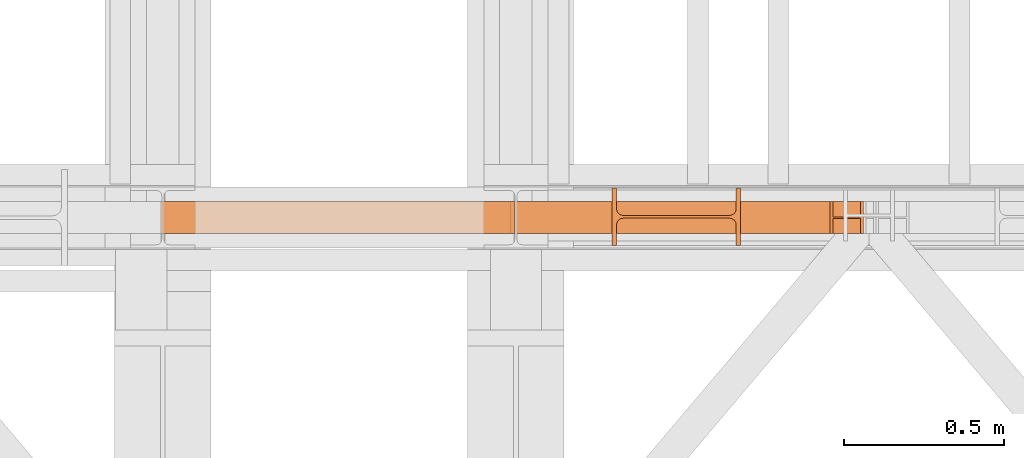
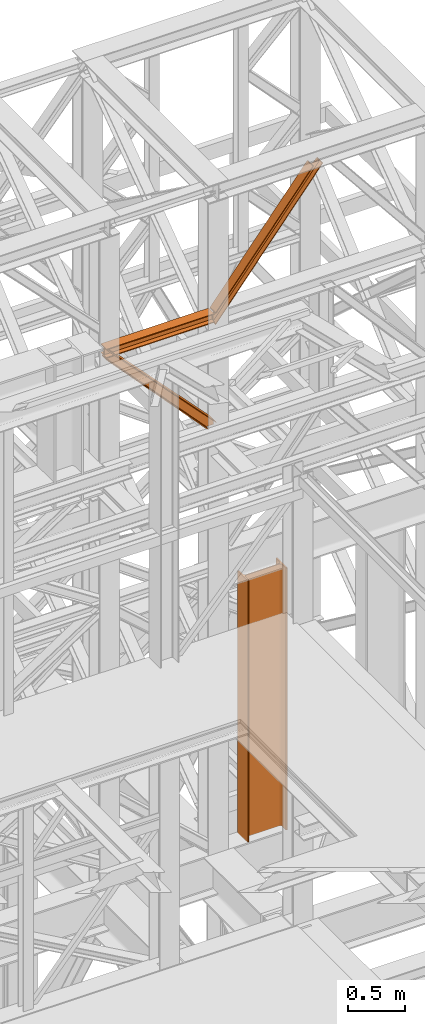
# One storey, part 154 of 208: 4 proxies.
"""IFC2X3 building model written with IfcOpenShell, lengths in millimetres."""

import ifcopenshell
import ifcopenshell.guid

model = None  # the IFC model being written
_history = None  # IfcOwnerHistory: only IFC2X3 demands one
_inside = {}  # id of a spatial element -> (the spatial element, [elements in it])
_under = {}  # id of a project, library or spatial element -> (it, [spatial elements below it])
_declared = {}  # id of a project -> (the project, [libraries it declares])
_typed = {}  # id of a type object -> (the type object, [elements of that type])
_made_of = {}  # id of a material, layer set ... -> (it, [elements and type objects made of it])


def new_model(schema):
    """Start an empty IFC model of exactly this schema.

    Asked for "IFC4X3", IfcOpenShell would pick the latest addendum, in which some entities
    have other attributes; the version numbers below select the first issue.
    IFC2X3 requires an IfcOwnerHistory on every rooted entity: one is made here for all.
    """
    global model, _history
    if schema == "IFC4X3":
        model = ifcopenshell.file(schema_version=(4, 3, 0, 0))
    else:
        model = ifcopenshell.file(schema=schema)
    _inside.clear()
    _under.clear()
    _declared.clear()
    _typed.clear()
    _made_of.clear()
    _history = None
    if model.schema == "IFC2X3":
        org = make("IfcOrganization", Name="unknown")
        user = make(
            "IfcPersonAndOrganization",
            ThePerson=make("IfcPerson", FamilyName="unknown"),
            TheOrganization=org,
        )
        app = make(
            "IfcApplication",
            ApplicationDeveloper=org,
            Version="unknown",
            ApplicationFullName="unknown",
            ApplicationIdentifier="unknown",
        )
        _history = make(
            "IfcOwnerHistory",
            OwningUser=user,
            OwningApplication=app,
            ChangeAction="ADDED",
            CreationDate=0,
        )
    return model


def make(cls, **values):
    """One entity of the class cls with the attributes given. An attribute that is None is left unset."""
    return model.create_entity(
        cls, **{name: value for name, value in values.items() if value is not None}
    )


def entity(cls, *values):
    """Any entity or typed value of the class cls, its attributes in the order of the schema. None: left unset."""
    e = model.create_entity(cls)
    for i, value in enumerate(values):
        if value is not None:
            e[i] = value
    return e


def rooted(cls, **values):
    """An entity with a GlobalId (a new one), such as an element, a storey or a relation."""
    return make(cls, GlobalId=ifcopenshell.guid.new(), OwnerHistory=_history, **values)


def si_unit(unit_type, name, prefix=None):
    """IfcSIUnit, for example si_unit("LENGTHUNIT", "METRE", prefix="MILLI")."""
    return make("IfcSIUnit", UnitType=unit_type, Prefix=prefix, Name=name)


def converted_unit(unit_type, name, factor, base, dimensions=None, offset=None):
    """IfcConversionBasedUnit, such as the inch: factor (a typed value) times the base unit."""
    return make(
        "IfcConversionBasedUnit"
        if offset is None
        else "IfcConversionBasedUnitWithOffset",
        ConversionOffset=offset,
        Dimensions=None
        if dimensions is None
        else entity("IfcDimensionalExponents", *dimensions),
        UnitType=unit_type,
        Name=name,
        ConversionFactor=make(
            "IfcMeasureWithUnit", ValueComponent=factor, UnitComponent=base
        ),
    )


def assignment(units):
    """IfcUnitAssignment: the units of a project."""
    return None if units is None else make("IfcUnitAssignment", Units=units)


def point(xyz):
    """IfcCartesianPoint."""
    return None if xyz is None else make("IfcCartesianPoint", Coordinates=xyz)


def direction(xyz):
    """IfcDirection."""
    return None if xyz is None else make("IfcDirection", DirectionRatios=xyz)


def frame(location, z_axis=None, x_axis=None):
    """IfcAxis2Placement3D, a coordinate frame: its origin and axes. An axis left out is left unset."""
    return make(
        "IfcAxis2Placement3D",
        Location=point(location),
        Axis=direction(z_axis),
        RefDirection=direction(x_axis),
    )


def origin():
    """The frame at (0, 0, 0) with its axes left unset."""
    return frame((0.0, 0.0, 0.0))


def origin_with_axes():
    """The frame at (0, 0, 0) with the z axis (0, 0, 1) and the x axis (1, 0, 0) written out."""
    return frame((0.0, 0.0, 0.0), z_axis=(0.0, 0.0, 1.0), x_axis=(1.0, 0.0, 0.0))


def place(relative_to, where):
    """IfcLocalPlacement: puts the frame where relative to a parent placement (None: the world)."""
    return make(
        "IfcLocalPlacement", PlacementRelTo=relative_to, RelativePlacement=where
    )


def context(
    kind, dimensions, precision=None, world=None, true_north=None, identifier=None
):
    """IfcGeometricRepresentationContext, for example the 3D "Model" context."""
    return make(
        "IfcGeometricRepresentationContext",
        ContextIdentifier=identifier,
        ContextType=kind,
        CoordinateSpaceDimension=dimensions,
        Precision=precision,
        WorldCoordinateSystem=world,
        TrueNorth=true_north,
    )


def subcontext(parent, identifier, kind, view, scale=None):
    """IfcGeometricRepresentationSubContext, for example "Body" below "Model"."""
    return make(
        "IfcGeometricRepresentationSubContext",
        ContextIdentifier=identifier,
        ContextType=kind,
        ParentContext=parent,
        TargetScale=scale,
        TargetView=view,
    )


def project(units=None, contexts=None):
    """IfcProject with its units and contexts."""
    return rooted(
        "IfcProject",
        Name="project",
        RepresentationContexts=contexts,
        UnitsInContext=assignment(units),
    )


def spatial(cls, under=None, at=None, **own):
    """A site, building, storey or space (cls), placed at a placement, below another one or the project."""
    s = rooted(cls, ObjectPlacement=at, **own)
    if under is not None:
        _under.setdefault(under.id(), (under, []))[1].append(s)
    return s


def faces_of(points, faces, orient=None, outer=None):
    """IfcFace entities. A face is a list of loops; a loop is a list of indices into points, from 0.

    orient and outer hold one flag for each loop. By default every Orientation is true, the
    first loop of a face is its IfcFaceOuterBound and the others are IfcFaceBound.
    """
    made = []
    for i, loops in enumerate(faces):
        bounds = []
        for j, loop in enumerate(loops):
            is_outer = j == 0 if outer is None else outer[i][j]
            bounds.append(
                make(
                    "IfcFaceOuterBound" if is_outer else "IfcFaceBound",
                    Bound=make("IfcPolyLoop", Polygon=[points[k] for k in loop]),
                    Orientation=True if orient is None else orient[i][j],
                )
            )
        made.append(make("IfcFace", Bounds=bounds))
    return made


def faceted_brep(points, faces, orient=None, outer=None, voids=None):
    """IfcFacetedBrep: a solid bounded by flat faces; with voids (closed shells), ...WithVoids."""
    shared = [point(p) for p in points]
    hull = make("IfcClosedShell", CfsFaces=faces_of(shared, faces, orient, outer))
    if voids is None:
        return make("IfcFacetedBrep", Outer=hull)
    return make(
        "IfcFacetedBrepWithVoids",
        Outer=hull,
        Voids=[
            make(cls, CfsFaces=faces_of(shared, fs, o, b)) for cls, fs, o, b in voids
        ],
    )


def shape(context_of_items, identifier, shape_type, items):
    """IfcShapeRepresentation: the items that make up one representation, for example the "Body"."""
    return make(
        "IfcShapeRepresentation",
        ContextOfItems=context_of_items,
        RepresentationIdentifier=identifier,
        RepresentationType=shape_type,
        Items=items,
    )


def made_of(thing, what):
    """Note that an element or type object is made of a material, layer set ...; save() writes the relation."""
    if what is not None:
        _made_of.setdefault(what.id(), (what, []))[1].append(thing)
    return thing


def element(
    cls,
    number,
    at=None,
    inside=None,
    cuts=None,
    type_object=None,
    material=None,
    context=None,
    identifier="Body",
    shape_type=None,
    held_by="IfcProductDefinitionShape",
    body=None,
    shapes=None,
    **own,
):
    """One element of the class cls, such as IfcWall. Its Tag is "e" and its number.

    at: its placement. inside: the storey or other place that contains it. cuts: it is an
    opening in that element (IfcRelVoidsElement). A single representation is given by context,
    identifier, shape_type and body (its items); several are given by shapes. held_by: the class
    of the entity that holds the representations. save() writes the other relations.
    """
    e = rooted(cls, Tag="e%d" % number, ObjectPlacement=at, **own)
    if body is not None:
        shapes = [shape(context, identifier, shape_type, body)]
    if shapes is not None:
        e.Representation = make(held_by, Representations=shapes)
    if inside is not None:
        _inside.setdefault(inside.id(), (inside, []))[1].append(e)
    if cuts is not None:
        rooted(
            "IfcRelVoidsElement", RelatingBuildingElement=cuts, RelatedOpeningElement=e
        )
    if type_object is not None:
        _typed.setdefault(type_object.id(), (type_object, []))[1].append(e)
    return made_of(e, material)


def aggregate(whole, parts):
    """IfcRelAggregates: a whole, such as a stair, and the parts it consists of."""
    return rooted("IfcRelAggregates", RelatingObject=whole, RelatedObjects=parts)


def save(model, path):
    """Write the relations noted so far, then the file.

    IfcRelAggregates (storeys below a building ...), IfcRelContainedInSpatialStructure (elements
    in a storey), IfcRelDefinesByType, IfcRelAssociatesMaterial and IfcRelDeclares: one each for
    every whole, place, type object, material and project.
    """
    for whole, parts in _under.values():
        aggregate(whole, parts)
    for where, things in _inside.values():
        rooted(
            "IfcRelContainedInSpatialStructure",
            RelatedElements=things,
            RelatingStructure=where,
        )
    for kind, things in _typed.values():
        rooted("IfcRelDefinesByType", RelatedObjects=things, RelatingType=kind)
    for what, things in _made_of.values():
        rooted("IfcRelAssociatesMaterial", RelatedObjects=things, RelatingMaterial=what)
    for by, libraries in _declared.values():
        rooted("IfcRelDeclares", RelatingContext=by, RelatedDefinitions=libraries)
    model.write(path)


model = new_model("IFC2X3")

# Units and contexts
model_context = context("Model", 3, precision=1e-05, world=origin())
plan_context = context("Plan", 3, precision=1e-05, world=origin())
body_context = subcontext(model_context, "Body", "Model", "MODEL_VIEW")
ifc_project = project(units=[si_unit("LENGTHUNIT", "METRE", prefix="MILLI"), converted_unit("PLANEANGLEUNIT", "DEGREE", entity("IfcPlaneAngleMeasure", 0.0174532925199433), si_unit("PLANEANGLEUNIT", "RADIAN"), dimensions=[0, 0, 0, 0, 0, 0, 0]), si_unit("AREAUNIT", "SQUARE_METRE"), si_unit("VOLUMEUNIT", "CUBIC_METRE")], contexts=[model_context, plan_context])

# Building, storey
building_placement = place(None, origin())
building = spatial("IfcBuilding", under=ifc_project, at=building_placement, CompositionType="COMPLEX")
storey_placement = place(building_placement, origin_with_axes())
storey = spatial("IfcBuildingStorey", under=building, at=storey_placement, Name="Geschoss", CompositionType="ELEMENT")

# Proxies
proxy_1_placement = place(storey_placement, frame((6893.254968528654, -16050.07439031789, 5278.356417081654), z_axis=(0.0, 0.0, 1.0), x_axis=(1.0, 0.0, 0.0)))
element("IfcBuildingElementProxy", 1, at=proxy_1_placement, inside=storey, context=body_context, shape_type="Brep", body=[
    faceted_brep([(400.0100000000002, 180.0100000000002, 0.01000000000112777), (400.0100000000002, 180.0100000000002, 2800.009999999993), (386.5100000000002, 180.0100000000002, 2800.009999999993), (386.5100000000002, 180.0100000000002, 0.01000000000112777), (386.5100000000002, 180.0100000000002, 0.01000000000112777), (386.5100000000002, 180.0100000000002, 2800.009999999993), (386.5100000000002, 115.3100001907351, 2800.009999999993), (386.5100000000002, 115.3100001907351, 0.01000000000112777), (386.5100000000002, 115.3100001907351, 0.01000000000112777), (386.5100000000002, 115.3100001907351, 2800.009999999993), (385.4821152884242, 108.820665321733, 2800.009999999993), (385.4821152884242, 108.820665321733, 0.01000000000112777), (385.4821152884242, 108.820665321733, 0.01000000000112777), (385.4821152884242, 108.820665321733, 2800.009999999993), (382.49933091598, 102.9665306951119, 2800.009999999993), (382.49933091598, 102.9665306951119, 0.01000000000112777), (382.49933091598, 102.9665306951119, 0.01000000000112777), (382.49933091598, 102.9665306951119, 2800.009999999993), (377.8534694956243, 98.32066927475717, 2800.009999999993), (377.8534694956243, 98.32066927475717, 0.01000000000112777), (377.8534694956243, 98.32066927475717, 0.01000000000112777), (377.8534694956243, 98.32066927475717, 2800.009999999993), (371.9993348690032, 95.337884902312, 2800.009999999993), (371.9993348690032, 95.337884902312, 0.01000000000112777), (371.9993348690032, 95.337884902312, 0.01000000000112777), (371.9993348690032, 95.337884902312, 2800.009999999993), (365.5100000000002, 94.31000019073508, 2800.009999999993), (365.5100000000002, 94.31000019073508, 0.01000000000112777), (365.5100000000002, 94.31000019073508, 0.01000000000112777), (365.5100000000002, 94.31000019073508, 2800.009999999993), (34.51000000000022, 94.31000019073508, 2800.009999999993), (34.51000000000022, 94.31000019073508, 0.01000000000021828), (34.51000000000022, 94.31000019073508, 0.01000000000021828), (34.51000000000022, 94.31000019073508, 2800.009999999993), (28.02066513099817, 95.337884902312, 2800.009999999993), (28.02066513099817, 95.337884902312, 0.01000000000021828), (28.02066513099817, 95.337884902312, 0.01000000000021828), (28.02066513099817, 95.337884902312, 2800.009999999993), (22.16653050437708, 98.32066927475717, 2800.009999999993), (22.16653050437708, 98.32066927475717, 0.01000000000021828), (22.16653050437708, 98.32066927475717, 0.01000000000021828), (22.16653050437708, 98.32066927475717, 2800.009999999993), (17.52066908402139, 102.9665306951119, 2800.009999999993), (17.52066908402139, 102.9665306951119, 0.01000000000021828), (17.52066908402139, 102.9665306951119, 0.01000000000021828), (17.52066908402139, 102.9665306951119, 2800.009999999993), (14.53788471157623, 108.820665321733, 2800.009999999993), (14.53788471157623, 108.820665321733, 0.01000000000021828), (14.53788471157623, 108.820665321733, 0.01000000000021828), (14.53788471157623, 108.820665321733, 2800.009999999993), (13.51000000000022, 115.3100001907351, 2800.009999999993), (13.51000000000022, 115.3100001907351, 0.01000000000021828), (13.51000000000022, 115.3100001907351, 0.01000000000021828), (13.51000000000022, 115.3100001907351, 2800.009999999993), (13.51000000000022, 180.0100000000002, 2800.009999999993), (13.51000000000022, 180.0100000000002, 0.01000000000021828), (13.51000000000022, 180.0100000000002, 0.01000000000021828), (13.51000000000022, 180.0100000000002, 2800.009999999993), (0.01000000000021828, 180.0100000000002, 2800.009999999993), (0.01000000000021828, 180.0100000000002, 0.01000000000021828), (0.01000000000021828, 180.0100000000002, 0.01000000000021828), (0.01000000000021828, 180.0100000000002, 2800.009999999993), (0.01000000000021828, 0.01000000000021828, 2800.009999999993), (0.01000000000021828, 0.01000000000021828, 0.01000000000021828), (0.01000000000021828, 0.01000000000021828, 0.01000000000021828), (0.01000000000021828, 0.01000000000021828, 2800.009999999993), (13.51000000000022, 0.01000000000021828, 2800.009999999993), (13.51000000000022, 0.01000000000021828, 0.01000000000021828), (13.51000000000022, 0.01000000000021828, 0.01000000000021828), (13.51000000000022, 0.01000000000021828, 2800.009999999993), (13.51000000000022, 64.70999980926535, 2800.009999999993), (13.51000000000022, 64.70999980926535, 0.01000000000021828), (13.51000000000022, 64.70999980926535, 0.01000000000021828), (13.51000000000022, 64.70999980926535, 2800.009999999993), (14.53788471157623, 71.1993346782674, 2800.009999999993), (14.53788471157623, 71.1993346782674, 0.01000000000021828), (14.53788471157623, 71.1993346782674, 0.01000000000021828), (14.53788471157623, 71.1993346782674, 2800.009999999993), (17.52066908402139, 77.0534693048885, 2800.009999999993), (17.52066908402139, 77.0534693048885, 0.01000000000021828), (17.52066908402139, 77.0534693048885, 0.01000000000021828), (17.52066908402139, 77.0534693048885, 2800.009999999993), (22.16653050437708, 81.69933072524327, 2800.009999999993), (22.16653050437708, 81.69933072524327, 0.01000000000021828), (22.16653050437708, 81.69933072524327, 0.01000000000021828), (22.16653050437708, 81.69933072524327, 2800.009999999993), (28.02066513099817, 84.68211509768844, 2800.009999999993), (28.02066513099817, 84.68211509768844, 0.01000000000021828), (28.02066513099817, 84.68211509768844, 0.01000000000021828), (28.02066513099817, 84.68211509768844, 2800.009999999993), (34.51000000000022, 85.70999980926535, 2800.009999999993), (34.51000000000022, 85.70999980926535, 0.01000000000021828), (34.51000000000022, 85.70999980926535, 0.01000000000021828), (34.51000000000022, 85.70999980926535, 2800.009999999993), (365.5100000000002, 85.70999980926535, 2800.009999999993), (365.5100000000002, 85.70999980926535, 0.01000000000112777), (365.5100000000002, 85.70999980926535, 0.01000000000112777), (365.5100000000002, 85.70999980926535, 2800.009999999993), (370.9451817183826, 84.99438062176887, 2800.009999999993), (370.9451817183826, 84.99438062176887, 0.01000000000112777), (370.9451817183826, 84.99438062176887, 0.01000000000112777), (370.9451817183826, 84.99438062176887, 2800.009999999993), (376.0099693746442, 82.89647688400692, 2800.009999999993), (376.0099693746442, 82.89647688400692, 0.01000000000112777), (376.0099693746442, 82.89647688400692, 0.01000000000112777), (376.0099693746442, 82.89647688400692, 2800.009999999993), (380.3592424049184, 79.55924221418354, 2800.009999999993), (380.3592424049184, 79.55924221418354, 0.01000000000112777), (380.3592424049184, 79.55924221418354, 0.01000000000112777), (380.3592424049184, 79.55924221418354, 2800.009999999993), (383.6964770747418, 75.20996918390847, 2800.009999999993), (383.6964770747418, 75.20996918390847, 0.01000000000112777), (383.6964770747418, 75.20996918390847, 0.01000000000112777), (383.6964770747418, 75.20996918390847, 2800.009999999993), (385.7943808125056, 70.14518152764686, 2800.009999999993), (385.7943808125056, 70.14518152764686, 0.01000000000112777), (385.7943808125056, 70.14518152764686, 0.01000000000112777), (385.7943808125056, 70.14518152764686, 2800.009999999993), (386.5100000000002, 64.70999980926535, 2800.009999999993), (386.5100000000002, 64.70999980926535, 0.01000000000112777), (386.5100000000002, 64.70999980926535, 0.01000000000112777), (386.5100000000002, 64.70999980926535, 2800.009999999993), (386.5100000000002, 0.01000000000021828, 2800.009999999993), (386.5100000000002, 0.01000000000021828, 0.01000000000112777), (386.5100000000002, 0.01000000000021828, 0.01000000000112777), (386.5100000000002, 0.01000000000021828, 2800.009999999993), (400.0100000000002, 0.01000000000021828, 2800.009999999993), (400.0100000000002, 0.01000000000021828, 0.01000000000112777), (400.0100000000002, 0.01000000000021828, 0.01000000000112777), (400.0100000000002, 0.01000000000021828, 2800.009999999993), (400.0100000000002, 180.0100000000002, 2800.009999999993), (400.0100000000002, 180.0100000000002, 0.01000000000112777), (400.0100000000002, 180.0100000000002, 0.01000000000112777), (386.5100000000002, 180.0100000000002, 0.01000000000112777), (386.5100000000002, 115.3100001907351, 0.01000000000112777), (385.4821152884242, 108.820665321733, 0.01000000000112777), (382.49933091598, 102.9665306951119, 0.01000000000112777), (377.8534694956243, 98.32066927475717, 0.01000000000112777), (371.9993348690032, 95.337884902312, 0.01000000000112777), (365.5100000000002, 94.31000019073508, 0.01000000000112777), (34.51000000000022, 94.31000019073508, 0.01000000000021828), (28.02066513099817, 95.337884902312, 0.01000000000021828), (22.16653050437708, 98.32066927475717, 0.01000000000021828), (17.52066908402139, 102.9665306951119, 0.01000000000021828), (14.53788471157623, 108.820665321733, 0.01000000000021828), (13.51000000000022, 115.3100001907351, 0.01000000000021828), (13.51000000000022, 180.0100000000002, 0.01000000000021828), (0.01000000000021828, 180.0100000000002, 0.01000000000021828), (0.01000000000021828, 0.01000000000021828, 0.01000000000021828), (13.51000000000022, 0.01000000000021828, 0.01000000000021828), (13.51000000000022, 64.70999980926535, 0.01000000000021828), (14.53788471157623, 71.1993346782674, 0.01000000000021828), (17.52066908402139, 77.0534693048885, 0.01000000000021828), (22.16653050437708, 81.69933072524327, 0.01000000000021828), (28.02066513099817, 84.68211509768844, 0.01000000000021828), (34.51000000000022, 85.70999980926535, 0.01000000000021828), (365.5100000000002, 85.70999980926535, 0.01000000000112777), (370.9451817183826, 84.99438062176887, 0.01000000000112777), (376.0099693746442, 82.89647688400692, 0.01000000000112777), (380.3592424049184, 79.55924221418354, 0.01000000000112777), (383.6964770747418, 75.20996918390847, 0.01000000000112777), (385.7943808125056, 70.14518152764686, 0.01000000000112777), (386.5100000000002, 64.70999980926535, 0.01000000000112777), (386.5100000000002, 0.01000000000021828, 0.01000000000112777), (400.0100000000002, 0.01000000000021828, 0.01000000000112777), (400.0100000000002, 180.0100000000002, 2800.009999999993), (400.0100000000002, 0.01000000000021828, 2800.009999999993), (386.5100000000002, 0.01000000000021828, 2800.009999999993), (386.5100000000002, 64.70999980926535, 2800.009999999993), (385.7943808125056, 70.14518152764686, 2800.009999999993), (383.6964770747418, 75.20996918390847, 2800.009999999993), (380.3592424049184, 79.55924221418354, 2800.009999999993), (376.0099693746442, 82.89647688400692, 2800.009999999993), (370.9451817183826, 84.99438062176887, 2800.009999999993), (365.5100000000002, 85.70999980926535, 2800.009999999993), (34.51000000000022, 85.70999980926535, 2800.009999999993), (28.02066513099817, 84.68211509768844, 2800.009999999993), (22.16653050437708, 81.69933072524327, 2800.009999999993), (17.52066908402139, 77.0534693048885, 2800.009999999993), (14.53788471157623, 71.1993346782674, 2800.009999999993), (13.51000000000022, 64.70999980926535, 2800.009999999993), (13.51000000000022, 0.01000000000021828, 2800.009999999993), (0.01000000000021828, 0.01000000000021828, 2800.009999999993), (0.01000000000021828, 180.0100000000002, 2800.009999999993), (13.51000000000022, 180.0100000000002, 2800.009999999993), (13.51000000000022, 115.3100001907351, 2800.009999999993), (14.53788471157623, 108.820665321733, 2800.009999999993), (17.52066908402139, 102.9665306951119, 2800.009999999993), (22.16653050437708, 98.32066927475717, 2800.009999999993), (28.02066513099817, 95.337884902312, 2800.009999999993), (34.51000000000022, 94.31000019073508, 2800.009999999993), (365.5100000000002, 94.31000019073508, 2800.009999999993), (371.9993348690032, 95.337884902312, 2800.009999999993), (377.8534694956243, 98.32066927475717, 2800.009999999993), (382.49933091598, 102.9665306951119, 2800.009999999993), (385.4821152884242, 108.820665321733, 2800.009999999993), (386.5100000000002, 115.3100001907351, 2800.009999999993), (386.5100000000002, 180.0100000000002, 2800.009999999993)], [[[0, 1, 2, 3]], [[4, 5, 6, 7]], [[8, 9, 10, 11]], [[12, 13, 14, 15]], [[16, 17, 18, 19]], [[20, 21, 22, 23]], [[24, 25, 26, 27]], [[28, 29, 30, 31]], [[32, 33, 34, 35]], [[36, 37, 38, 39]], [[40, 41, 42, 43]], [[44, 45, 46, 47]], [[48, 49, 50, 51]], [[52, 53, 54, 55]], [[56, 57, 58, 59]], [[60, 61, 62, 63]], [[64, 65, 66, 67]], [[68, 69, 70, 71]], [[72, 73, 74, 75]], [[76, 77, 78, 79]], [[80, 81, 82, 83]], [[84, 85, 86, 87]], [[88, 89, 90, 91]], [[92, 93, 94, 95]], [[96, 97, 98, 99]], [[100, 101, 102, 103]], [[104, 105, 106, 107]], [[108, 109, 110, 111]], [[112, 113, 114, 115]], [[116, 117, 118, 119]], [[120, 121, 122, 123]], [[124, 125, 126, 127]], [[128, 129, 130, 131]], [[132, 133, 134, 135, 136, 137, 138, 139, 140, 141, 142, 143, 144, 145, 146, 147, 148, 149, 150, 151, 152, 153, 154, 155, 156, 157, 158, 159, 160, 161, 162, 163, 164]], [[165, 166, 167, 168, 169, 170, 171, 172, 173, 174, 175, 176, 177, 178, 179, 180, 181, 182, 183, 184, 185, 186, 187, 188, 189, 190, 191, 192, 193, 194, 195, 196, 197]]], orient=[[False], [False], [False], [False], [False], [False], [False], [False], [False], [False], [False], [False], [False], [False], [False], [False], [False], [False], [False], [False], [False], [False], [False], [False], [False], [False], [False], [False], [False], [False], [False], [False], [False], [False], [False]]),
])
proxy_2_placement = place(storey_placement, frame((5495.439888909063, -16012.50587051042, 9806.10571322234), z_axis=(0.0, 0.0, 1.0), x_axis=(1.0, 0.0, 0.0)))
element("IfcBuildingElementProxy", 2, at=proxy_2_placement, inside=storey, context=body_context, shape_type="Brep", body=[
    faceted_brep([(0.01000000000567525, 0.01000000000021828, 1099.356957502509), (1026.960887572572, 0.01000000001477019, 0.01000000000749424), (1013.304550507357, 0.01000000000021828, 0.01000000000749424), (0.01000000000567525, 0.01000000000021828, 1089.51445314314), (0.01000000000567525, 0.01000000000021828, 1089.51445314314), (1013.304550507357, 0.01000000000021828, 0.01000000000749424), (1013.304550507357, 100.0100000000075, 0.01000000000385626), (0.01000000000476575, 100.0100000000075, 1089.514453143136), (0.01000000000476575, 100.0100000000075, 1089.514453143136), (1013.304550507357, 100.0100000000075, 0.01000000000385626), (1026.960887572572, 100.0100000000148, 0.01000000000749424), (0.01000000000567525, 100.0100000000002, 1099.356957502507), (0.01000000000567525, 100.0100000000002, 1099.356957502507), (1026.960887572572, 100.0100000000148, 0.01000000000749424), (1026.960887572586, 52.51000000001477, 0.01000000000021828), (0.01000000000021828, 52.51000000000749, 1099.356957502503), (0.01000000000021828, 52.51000000000749, 1099.356957502503), (1026.960887572586, 52.51000000001477, 0.01000000000021828), (1099.938049772678, 52.51000000001477, 0.01000000000749424), (1099.938049772685, 52.51000000001477, 44.7291489489744), (0.01000000000567525, 52.51000000000022, 1198.221864630246), (0.01000000000567525, 52.51000000000022, 1198.221864630246), (1099.938049772685, 52.51000000001477, 44.7291489489744), (1099.938049772685, 100.0100000000075, 44.7291489489744), (0.01000000000385626, 100.0100000000002, 1198.221864630245), (0.01000000000385626, 100.0100000000002, 1198.221864630245), (1099.938049772685, 100.0100000000075, 44.7291489489744), (1099.938049772685, 100.0100000000075, 54.33717683089526), (0.01000000000567525, 100.0100000000002, 1212.436319868004), (0.01000000000567525, 100.0100000000002, 1212.436319868004), (1099.938049772685, 100.0100000000075, 54.33717683089526), (1099.938049772685, 0.01000000001477019, 54.33717683089526), (0.01000000000385626, 0.01000000000021828, 1212.436319868006), (0.01000000000385626, 0.01000000000021828, 1212.436319868006), (1099.938049772685, 0.01000000001477019, 54.33717683089526), (1099.938049772685, 0.01000000001477019, 44.7291489489744), (0.01000000000567525, 0.01000000000021828, 1198.221864630246), (0.01000000000567525, 0.01000000000021828, 1198.221864630246), (1099.938049772685, 0.01000000001477019, 44.7291489489744), (1099.938049772685, 47.51000000001477, 44.72914894897076), (0.01000000000567525, 47.51000000000022, 1198.221864630243), (0.01000000000567525, 47.51000000000022, 1198.221864630243), (1099.938049772685, 47.51000000001477, 44.72914894897076), (1099.938049772693, 47.51000000002205, 0.01000000000749424), (1026.960887572572, 47.51000000001477, 0.01000000000749424), (0.01000000000476575, 47.51000000000204, 1099.35695750251), (0.01000000000476575, 47.51000000000204, 1099.35695750251), (1026.960887572572, 47.51000000001477, 0.01000000000749424), (1026.960887572572, 0.01000000001477019, 0.01000000000749424), (0.01000000000567525, 0.01000000000021828, 1099.356957502509), (1099.938049772693, 47.51000000002205, 0.01000000000749424), (1099.938049772685, 47.51000000001477, 44.72914894897076), (1099.938049772685, 0.01000000001477019, 44.7291489489744), (1099.938049772685, 0.01000000001477019, 54.33717683089526), (1099.938049772685, 100.0100000000075, 54.33717683089526), (1099.938049772685, 100.0100000000075, 44.7291489489744), (1099.938049772685, 52.51000000001477, 44.7291489489744), (1099.938049772678, 52.51000000001477, 0.01000000000749424), (1026.960887572572, 0.01000000001477019, 0.01000000000749424), (1026.960887572572, 47.51000000001477, 0.01000000000749424), (1099.938049772693, 47.51000000002205, 0.01000000000749424), (1099.938049772678, 52.51000000001477, 0.01000000000749424), (1026.960887572586, 52.51000000001477, 0.01000000000021828), (1026.960887572572, 100.0100000000148, 0.01000000000749424), (1013.304550507357, 100.0100000000075, 0.01000000000385626), (1013.304550507357, 0.01000000000021828, 0.01000000000749424), (0.01000000000567525, 0.01000000000021828, 1089.51445314314), (0.01000000000476575, 100.0100000000075, 1089.514453143136), (0.01000000000567525, 100.0100000000002, 1099.356957502507), (0.01000000000021828, 52.51000000000749, 1099.356957502503), (0.01000000000567525, 52.51000000000022, 1198.221864630246), (0.01000000000385626, 100.0100000000002, 1198.221864630245), (0.01000000000567525, 100.0100000000002, 1212.436319868004), (0.01000000000385626, 0.01000000000021828, 1212.436319868006), (0.01000000000567525, 0.01000000000021828, 1198.221864630246), (0.01000000000567525, 47.51000000000022, 1198.221864630243), (0.01000000000476575, 47.51000000000204, 1099.35695750251), (0.01000000000567525, 0.01000000000021828, 1099.356957502509)], [[[0, 1, 2, 3]], [[4, 5, 6, 7]], [[8, 9, 10, 11]], [[12, 13, 14, 15]], [[16, 17, 18, 19, 20]], [[21, 22, 23, 24]], [[25, 26, 27, 28]], [[29, 30, 31, 32]], [[33, 34, 35, 36]], [[37, 38, 39, 40]], [[41, 42, 43, 44, 45]], [[46, 47, 48, 49]], [[50, 51, 52, 53, 54, 55, 56, 57]], [[58, 59, 60, 61, 62, 63, 64, 65]], [[66, 67, 68, 69, 70, 71, 72, 73, 74, 75, 76, 77]]], orient=[[False], [False], [False], [False], [False], [False], [False], [False], [False], [False], [False], [False], [False], [False], [False]]),
])
proxy_3_placement = place(storey_placement, frame((6590.264581112975, -16012.57439031789, 10898.19724722128), z_axis=(0.0, 0.0, 1.0), x_axis=(1.0, 0.0, 0.0)))
element("IfcBuildingElementProxy", 3, at=proxy_3_placement, inside=storey, context=body_context, shape_type="Brep", body=[
    faceted_brep([(1077.154510505558, 100.010000000002, 1351.802811472526), (0.01000000000112777, 100.0100000000002, 10.80333201053145), (0.01000000000112777, 100.0100000000002, 0.01000000000203727), (1085.82363645391, 100.010000000002, 1351.802811472526), (1085.82363645391, 100.010000000002, 1351.802811472526), (0.01000000000112777, 100.0100000000002, 0.01000000000203727), (0.01000000000203727, 0.01000000000021828, 0.01000000000021828), (1085.82363645391, 0.01000000000203727, 1351.802811472526), (1085.82363645391, 0.01000000000203727, 1351.802811472526), (0.01000000000203727, 0.01000000000021828, 0.01000000000021828), (0.01000000000203727, 0.01000000000021828, 10.80333201053145), (1077.154510505556, 0.01000000000203727, 1351.802811472526), (1077.154510505556, 0.01000000000203727, 1351.802811472526), (0.01000000000203727, 0.01000000000021828, 10.80333201053145), (0.01000000000112777, 47.51000000000022, 10.80333201053145), (1077.154510505556, 47.51000000000204, 1351.802811472526), (1077.154510505556, 47.51000000000204, 1351.802811472526), (0.01000000000112777, 47.51000000000022, 10.80333201053145), (0.01000000000112777, 47.51000000000022, 118.7365654617024), (990.4633931343651, 47.51000000000204, 1351.802811472526), (990.4633931343651, 47.51000000000204, 1351.802811472526), (0.01000000000112777, 47.51000000000022, 118.7365654617024), (0.01000000000021828, 0.01000000000021828, 118.7365654617042), (990.4633931343669, 0.01000000000203727, 1351.802811472526), (990.4633931343669, 0.01000000000203727, 1351.802811472526), (0.01000000000021828, 0.01000000000021828, 118.7365654617042), (0.01000000000112777, 0.01000000000021828, 129.5298790925499), (981.7942969826954, 0.01000000000203727, 1351.802811472526), (981.7942969826954, 0.01000000000203727, 1351.802811472526), (0.01000000000112777, 0.01000000000021828, 129.5298790925499), (0.01000000000203727, 100.0100000000002, 129.5298790925535), (981.7942969826945, 100.010000000002, 1351.802811472526), (981.7942969826945, 100.010000000002, 1351.802811472526), (0.01000000000203727, 100.0100000000002, 129.5298790925535), (0.01000000000112777, 100.0100000000002, 118.7365654617042), (990.4633931343651, 100.010000000002, 1351.802811472526), (990.4633931343651, 100.010000000002, 1351.802811472526), (0.01000000000112777, 100.0100000000002, 118.7365654617042), (0.01000000000203727, 52.51000000000022, 118.7365654617061), (990.4633931343669, 52.51000000000204, 1351.802811472526), (990.4633931343669, 52.51000000000204, 1351.802811472526), (0.01000000000203727, 52.51000000000022, 118.7365654617061), (0.01000000000203727, 52.51000000000022, 10.80333201053145), (1077.154510505556, 52.51000000000204, 1351.802811472526), (1077.154510505556, 52.51000000000204, 1351.802811472526), (0.01000000000203727, 52.51000000000022, 10.80333201053145), (0.01000000000112777, 100.0100000000002, 10.80333201053145), (1077.154510505558, 100.010000000002, 1351.802811472526), (1085.82363645391, 100.010000000002, 1351.802811472526), (1085.82363645391, 0.01000000000203727, 1351.802811472526), (1077.154510505556, 0.01000000000203727, 1351.802811472526), (1077.154510505556, 47.51000000000204, 1351.802811472526), (990.4633931343651, 47.51000000000204, 1351.802811472526), (990.4633931343669, 0.01000000000203727, 1351.802811472526), (981.7942969826954, 0.01000000000203727, 1351.802811472526), (981.7942969826945, 100.010000000002, 1351.802811472526), (990.4633931343651, 100.010000000002, 1351.802811472526), (990.4633931343669, 52.51000000000204, 1351.802811472526), (1077.154510505556, 52.51000000000204, 1351.802811472526), (1077.154510505558, 100.010000000002, 1351.802811472526), (0.01000000000112777, 100.0100000000002, 10.80333201053145), (0.01000000000203727, 52.51000000000022, 10.80333201053145), (0.01000000000203727, 52.51000000000022, 118.7365654617061), (0.01000000000112777, 100.0100000000002, 118.7365654617042), (0.01000000000203727, 100.0100000000002, 129.5298790925535), (0.01000000000112777, 0.01000000000021828, 129.5298790925499), (0.01000000000021828, 0.01000000000021828, 118.7365654617042), (0.01000000000112777, 47.51000000000022, 118.7365654617024), (0.01000000000112777, 47.51000000000022, 10.80333201053145), (0.01000000000203727, 0.01000000000021828, 10.80333201053145), (0.01000000000203727, 0.01000000000021828, 0.01000000000021828), (0.01000000000112777, 100.0100000000002, 0.01000000000203727)], [[[0, 1, 2, 3]], [[4, 5, 6, 7]], [[8, 9, 10, 11]], [[12, 13, 14, 15]], [[16, 17, 18, 19]], [[20, 21, 22, 23]], [[24, 25, 26, 27]], [[28, 29, 30, 31]], [[32, 33, 34, 35]], [[36, 37, 38, 39]], [[40, 41, 42, 43]], [[44, 45, 46, 47]], [[48, 49, 50, 51, 52, 53, 54, 55, 56, 57, 58, 59]], [[60, 61, 62, 63, 64, 65, 66, 67, 68, 69, 70, 71]]], orient=[[False], [False], [False], [False], [False], [False], [False], [False], [False], [False], [False], [False], [False], [False]]),
])
proxy_4_placement = place(storey_placement, frame((5486.221305444389, -16012.50587051043, 10926.99005869381), z_axis=(0.0, 0.0, 1.0), x_axis=(1.0, 0.0, 0.0)))
element("IfcBuildingElementProxy", 4, at=proxy_4_placement, inside=storey, context=body_context, shape_type="Brep", body=[
    faceted_brep([(1091.936120735611, 0.01000000000021828, 88.01000000000022), (1091.936120735611, 0.01000000000021828, 96.01000000000022), (1091.936120735611, 100.0100000000002, 96.01000000000022), (1091.936120735611, 100.0100000000002, 88.01000000000022), (1091.936120735611, 52.51000000000022, 88.01000000000022), (1091.936120735611, 52.51000000000022, 8.010000000000218), (1091.936120735611, 100.0100000000002, 8.010000000000218), (1091.936120735611, 100.0100000000002, 0.01000000000021828), (1091.936120735611, 0.01000000000021828, 0.01000000000021828), (1091.936120735611, 0.01000000000021828, 8.010000000000218), (1091.936120735611, 47.51000000000022, 8.010000000000218), (1091.936120735611, 47.51000000000022, 88.01000000000022), (1091.936120735611, 0.01000000000021828, 96.01000000000022), (1091.936120735611, 0.01000000000021828, 88.01000000000022), (0.009999999999308784, 0.01000000000385626, 88.01000000000022), (0.009999999999308784, 0.01000000000385626, 96.01000000000022), (1091.936120735611, 100.0100000000002, 96.01000000000022), (1091.936120735611, 0.01000000000021828, 96.01000000000022), (0.009999999999308784, 0.01000000000385626, 96.01000000000022), (0.009999999999308784, 100.0100000000039, 96.01000000000022), (1091.936120735611, 100.0100000000002, 88.01000000000022), (1091.936120735611, 100.0100000000002, 96.01000000000022), (0.009999999999308784, 100.0100000000039, 96.01000000000022), (0.009999999999308784, 100.0100000000039, 88.01000000000022), (1091.936120735611, 52.51000000000022, 88.01000000000022), (1091.936120735611, 100.0100000000002, 88.01000000000022), (0.009999999999308784, 100.0100000000039, 88.01000000000022), (0.009999999999308784, 52.51000000000386, 88.01000000000022), (1091.936120735611, 52.51000000000022, 8.010000000000218), (1091.936120735611, 52.51000000000022, 88.01000000000022), (0.009999999999308784, 52.51000000000386, 88.01000000000022), (0.009999999999308784, 52.51000000000386, 8.010000000000218), (1091.936120735611, 100.0100000000002, 8.010000000000218), (1091.936120735611, 52.51000000000022, 8.010000000000218), (0.009999999999308784, 52.51000000000386, 8.010000000000218), (0.009999999999308784, 100.0100000000039, 8.010000000000218), (1091.936120735611, 100.0100000000002, 0.01000000000021828), (1091.936120735611, 100.0100000000002, 8.010000000000218), (0.009999999999308784, 100.0100000000039, 8.010000000000218), (0.009999999999308784, 100.0100000000039, 0.01000000000021828), (1091.936120735611, 0.01000000000021828, 0.01000000000021828), (1091.936120735611, 100.0100000000002, 0.01000000000021828), (0.009999999999308784, 100.0100000000039, 0.01000000000021828), (0.009999999999308784, 0.01000000000385626, 0.01000000000021828), (1091.936120735611, 0.01000000000021828, 8.010000000000218), (1091.936120735611, 0.01000000000021828, 0.01000000000021828), (0.009999999999308784, 0.01000000000385626, 0.01000000000021828), (0.009999999999308784, 0.01000000000385626, 8.010000000000218), (1091.936120735611, 47.51000000000022, 8.010000000000218), (1091.936120735611, 0.01000000000021828, 8.010000000000218), (0.009999999999308784, 0.01000000000385626, 8.010000000000218), (0.009999999999308784, 47.51000000000386, 8.010000000000218), (1091.936120735611, 47.51000000000022, 88.01000000000022), (1091.936120735611, 47.51000000000022, 8.010000000000218), (0.009999999999308784, 47.51000000000386, 8.010000000000218), (0.009999999999308784, 47.51000000000386, 88.01000000000022), (1091.936120735611, 0.01000000000021828, 88.01000000000022), (1091.936120735611, 47.51000000000022, 88.01000000000022), (0.009999999999308784, 47.51000000000386, 88.01000000000022), (0.009999999999308784, 0.01000000000385626, 88.01000000000022), (0.009999999999308784, 0.01000000000385626, 88.01000000000022), (0.009999999999308784, 47.51000000000386, 88.01000000000022), (0.009999999999308784, 47.51000000000386, 8.010000000000218), (0.009999999999308784, 0.01000000000385626, 8.010000000000218), (0.009999999999308784, 0.01000000000385626, 0.01000000000021828), (0.009999999999308784, 100.0100000000039, 0.01000000000021828), (0.009999999999308784, 100.0100000000039, 8.010000000000218), (0.009999999999308784, 52.51000000000386, 8.010000000000218), (0.009999999999308784, 52.51000000000386, 88.01000000000022), (0.009999999999308784, 100.0100000000039, 88.01000000000022), (0.009999999999308784, 100.0100000000039, 96.01000000000022), (0.009999999999308784, 0.01000000000385626, 96.01000000000022)], [[[0, 1, 2, 3, 4, 5, 6, 7, 8, 9, 10, 11]], [[12, 13, 14, 15]], [[16, 17, 18, 19]], [[20, 21, 22, 23]], [[24, 25, 26, 27]], [[28, 29, 30, 31]], [[32, 33, 34, 35]], [[36, 37, 38, 39]], [[40, 41, 42, 43]], [[44, 45, 46, 47]], [[48, 49, 50, 51]], [[52, 53, 54, 55]], [[56, 57, 58, 59]], [[60, 61, 62, 63, 64, 65, 66, 67, 68, 69, 70, 71]]], orient=[[False], [False], [False], [False], [False], [False], [False], [False], [False], [False], [False], [False], [False], [False]]),
])

save(model, "model.ifc")
